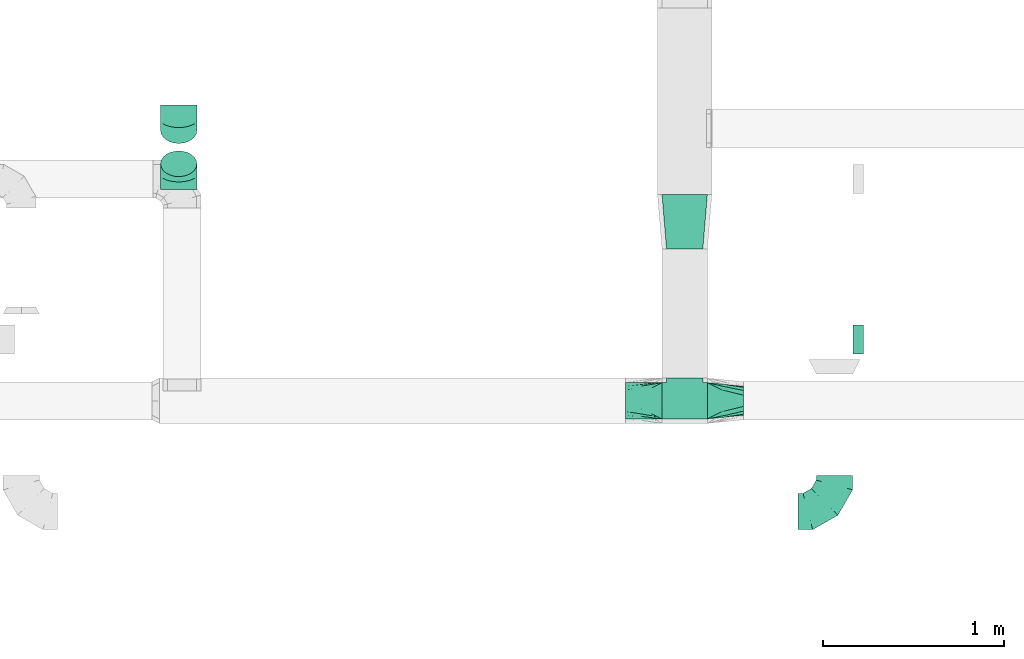
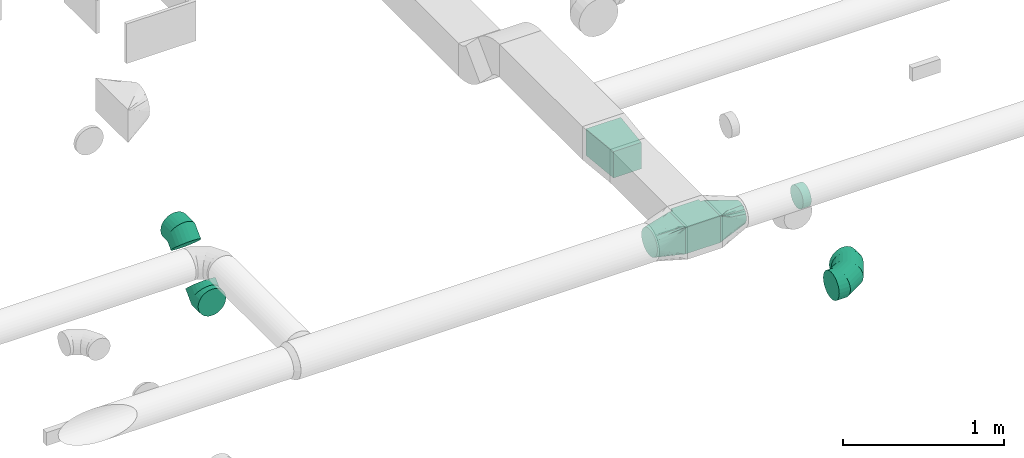
# One storey, part 37 of 62: 8 flow fittings.
"""IFC2X3 building model written with IfcOpenShell, lengths in millimetres."""

from ifc_helpers import new_model, entity, si_unit, converted_unit, derived_unit, direction, frame, origin, place, context, subcontext, project, spatial, polyline, outline, extrude, faceted_brep, source, transform, mapped, material, type_object, type_shapes, element, save


model = new_model("IFC2X3")

# Units and contexts
model_context = context("Model", 3, precision=0.01, world=origin(), true_north=direction((6.12303176911189e-17, 1.0)))
body_context = subcontext(model_context, "Body", "Model", "MODEL_VIEW")
ifc_project = project(units=[si_unit("LENGTHUNIT", "METRE", prefix="MILLI"), si_unit("AREAUNIT", "SQUARE_METRE"), si_unit("VOLUMEUNIT", "CUBIC_METRE"), converted_unit("PLANEANGLEUNIT", "DEGREE", entity("IfcRatioMeasure", 0.0174532925199433), si_unit("PLANEANGLEUNIT", "RADIAN"), dimensions=[0, 0, 0, 0, 0, 0, 0]), si_unit("MASSUNIT", "GRAM", prefix="KILO"), derived_unit("MASSDENSITYUNIT", [(si_unit("MASSUNIT", "GRAM", prefix="KILO"), 1), (si_unit("LENGTHUNIT", "METRE"), -3)]), derived_unit("MOMENTOFINERTIAUNIT", [(si_unit("LENGTHUNIT", "METRE"), 4)]), si_unit("TIMEUNIT", "SECOND"), si_unit("FREQUENCYUNIT", "HERTZ"), si_unit("THERMODYNAMICTEMPERATUREUNIT", "DEGREE_CELSIUS"), derived_unit("THERMALTRANSMITTANCEUNIT", [(si_unit("MASSUNIT", "GRAM", prefix="KILO"), 1), (si_unit("THERMODYNAMICTEMPERATUREUNIT", "KELVIN"), -1), (si_unit("TIMEUNIT", "SECOND"), -3)]), derived_unit("VOLUMETRICFLOWRATEUNIT", [(si_unit("LENGTHUNIT", "METRE"), 3), (si_unit("TIMEUNIT", "SECOND"), -1)]), derived_unit("MASSFLOWRATEUNIT", [(si_unit("MASSUNIT", "GRAM", prefix="KILO"), 1), (si_unit("TIMEUNIT", "SECOND"), -1)]), derived_unit("ROTATIONALFREQUENCYUNIT", [(si_unit("TIMEUNIT", "SECOND"), -1)]), si_unit("ELECTRICCURRENTUNIT", "AMPERE"), si_unit("ELECTRICVOLTAGEUNIT", "VOLT"), si_unit("POWERUNIT", "WATT"), si_unit("FORCEUNIT", "NEWTON", prefix="KILO"), si_unit("ILLUMINANCEUNIT", "LUX"), si_unit("LUMINOUSFLUXUNIT", "LUMEN"), si_unit("LUMINOUSINTENSITYUNIT", "CANDELA"), derived_unit("USERDEFINED", [(si_unit("MASSUNIT", "GRAM", prefix="KILO"), -1), (si_unit("LENGTHUNIT", "METRE"), -2), (si_unit("TIMEUNIT", "SECOND"), 3), (si_unit("LUMINOUSFLUXUNIT", "LUMEN"), 1)]), derived_unit("LINEARVELOCITYUNIT", [(si_unit("LENGTHUNIT", "METRE"), 1), (si_unit("TIMEUNIT", "SECOND"), -1)]), si_unit("PRESSUREUNIT", "PASCAL"), derived_unit("USERDEFINED", [(si_unit("LENGTHUNIT", "METRE"), -2), (si_unit("MASSUNIT", "GRAM", prefix="KILO"), 1), (si_unit("TIMEUNIT", "SECOND"), -2)]), derived_unit("LINEARFORCEUNIT", [(si_unit("MASSUNIT", "GRAM", prefix="KILO"), 1), (si_unit("LENGTHUNIT", "METRE"), 1), (si_unit("TIMEUNIT", "SECOND"), -2), (si_unit("LENGTHUNIT", "METRE"), -1)]), derived_unit("PLANARFORCEUNIT", [(si_unit("MASSUNIT", "GRAM", prefix="KILO"), 1), (si_unit("LENGTHUNIT", "METRE"), 1), (si_unit("TIMEUNIT", "SECOND"), -2), (si_unit("LENGTHUNIT", "METRE"), -2)])], contexts=[model_context])

# Site, building, storey
site_placement = place(None, origin())
site = spatial("IfcSite", under=ifc_project, at=site_placement, CompositionType="ELEMENT")
building_placement = place(site_placement, origin())
building = spatial("IfcBuilding", under=site, at=building_placement, CompositionType="ELEMENT")
storey_placement = place(building_placement, frame((0.0, 0.0, 24000.0)))
storey = spatial("IfcBuildingStorey", under=building, at=storey_placement, CompositionType="ELEMENT", Elevation=24000.0)

# Flow fittings
ifc_material = material()
duct_fitting_type_1 = type_object("IfcDuctFittingType", PredefinedType="NOTDEFINED", material=ifc_material)
shared_shape_1 = source(origin(), body_context, "Body", "SweptSolid", [
    extrude(outline(polyline([(-125.0, 43.75), (-125.0, -156.25), (125.0, -156.25), (125.0, 43.75), (100.0, 43.75), (100.0, 68.75), (-100.0, 68.75), (-100.0, 43.75), (-125.0, 43.75)])), frame((0.0, -56.25, -100.0), z_axis=(0.0, 0.0, -1.0), x_axis=(1.0, 0.0, 0.0)), (0.0, 0.0, -1.0), 200.0),
])
type_shapes(duct_fitting_type_1, [shared_shape_1])
flow_fitting_1_placement = place(storey_placement, frame((55179.59, 2775.97, 3550.0), z_axis=(0.0, 0.0, 1.0), x_axis=(-1.0, 0.0, 0.0)))
element("IfcFlowFitting", 1, at=flow_fitting_1_placement, inside=storey, type_object=duct_fitting_type_1, material=ifc_material, context=body_context, shape_type="MappedRepresentation", body=[
    mapped(shared_shape_1, transform((0.0, 0.0, 0.0), scale=1.0)),
])
duct_fitting_type_2 = type_object("IfcDuctFittingType", PredefinedType="NOTDEFINED", material=ifc_material)
shared_shape_2 = source(origin(), body_context, "Body", "SweptSolid", [
    extrude(outline(polyline([(-141.18, -112.11), (159.86, -112.11), (139.1, 137.03), (-157.79, 87.2), (-141.18, -112.11)])), frame((150.0, 0.0, -100.0), z_axis=(0.0, 0.0, 1.0), x_axis=(0.996545758244879, -0.0830454798537418, 0.0)), (0.0, 0.0, 1.0), 200.0),
])
type_shapes(duct_fitting_type_2, [shared_shape_2])
flow_fitting_2_placement = place(storey_placement, frame((55179.59, 3612.24, 3550.0), z_axis=(0.0, 0.0, 1.0), x_axis=(0.0, 1.0, 0.0)))
element("IfcFlowFitting", 2, at=flow_fitting_2_placement, inside=storey, type_object=duct_fitting_type_2, material=ifc_material, context=body_context, shape_type="MappedRepresentation", body=[
    mapped(shared_shape_2, transform((0.0, 0.0, 0.0), scale=1.0)),
])
duct_fitting_type_3 = type_object("IfcDuctFittingType", PredefinedType="NOTDEFINED", material=ifc_material)
shared_shape_3 = source(origin(), body_context, "Body", "Brep", [
    faceted_brep([(-200.0, 0.0, -100.0), (-200.0, -25.88, -96.59), (-200.0, -50.0, -86.6), (-200.0, -70.71, -70.71), (-200.0, -86.6, -50.0), (-200.0, -96.59, -25.88), (-200.0, -100.0, 0.0), (-200.0, -96.59, 25.88), (-200.0, -86.6, 50.0), (-200.0, -70.71, 70.71), (-200.0, -50.0, 86.6), (-200.0, -25.88, 96.59), (-200.0, 0.0, 100.0), (-200.0, 25.88, 96.59), (-200.0, 50.0, 86.6), (-200.0, 70.71, 70.71), (-200.0, 86.6, 50.0), (-200.0, 96.59, 25.88), (-200.0, 100.0, 0.0), (-200.0, 96.59, -25.88), (-200.0, 86.6, -50.0), (-200.0, 70.71, -70.71), (-200.0, 50.0, -86.6), (-200.0, 25.88, -96.59), (-153.35, 25.88, 96.59), (-159.81, 50.0, 86.6), (-146.41, 0.0, 100.0), (-165.36, 70.71, 70.71), (-172.29, 96.59, 25.88), (-173.21, 100.0, 0.0), (-169.62, 86.6, 50.0), (-169.62, 86.6, -50.0), (-165.36, 70.71, -70.71), (-172.29, 96.59, -25.88), (-153.35, 25.88, -96.59), (-146.41, 0.0, -100.0), (-159.81, 50.0, -86.6), (-139.48, -25.88, -96.59), (-133.01, -50.0, -86.6), (-127.46, -70.71, -70.71), (-123.21, -86.6, -50.0), (-120.53, -96.59, -25.88), (-119.62, -100.0, 0.0), (-120.53, -96.59, 25.88), (-123.21, -86.6, 50.0), (-127.46, -70.71, 70.71), (-133.01, -50.0, 86.6), (-139.48, -25.88, 96.59), (-72.54, 72.54, 96.59), (-90.19, 90.19, 86.6), (-53.59, 53.59, 100.0), (-105.35, 105.35, 70.71), (-116.99, 116.99, 50.0), (-124.3, 124.3, 25.88), (-126.79, 126.79, 0.0), (-124.3, 124.3, -25.88), (-116.99, 116.99, -50.0), (-105.35, 105.35, -70.71), (-72.54, 72.54, -96.59), (-53.59, 53.59, -100.0), (-90.19, 90.19, -86.6), (-34.64, 34.64, -96.59), (-16.99, 16.99, -86.6), (-1.83, 1.83, -70.71), (9.81, -9.81, -50.0), (17.12, -17.12, -25.88), (19.62, -19.62, 0.0), (17.12, -17.12, 25.88), (9.81, -9.81, 50.0), (-1.83, 1.83, 70.71), (-16.99, 16.99, 86.6), (-34.64, 34.64, 96.59), (-25.88, 153.35, 96.59), (-50.0, 159.81, 86.6), (0.0, 146.41, 100.0), (-70.71, 165.36, 70.71), (-86.6, 169.62, 50.0), (-96.59, 172.29, 25.88), (-100.0, 173.21, 0.0), (-96.59, 172.29, -25.88), (-86.6, 169.62, -50.0), (-70.71, 165.36, -70.71), (-25.88, 153.35, -96.59), (0.0, 146.41, -100.0), (-50.0, 159.81, -86.6), (25.88, 139.48, -96.59), (50.0, 133.01, -86.6), (70.71, 127.46, -70.71), (86.6, 123.21, -50.0), (96.59, 120.53, -25.88), (100.0, 119.62, 0.0), (96.59, 120.53, 25.88), (86.6, 123.21, 50.0), (70.71, 127.46, 70.71), (50.0, 133.01, 86.6), (25.88, 139.48, 96.59), (-25.88, 200.0, -96.59), (-50.0, 200.0, -86.6), (-70.71, 200.0, -70.71), (-86.6, 200.0, -50.0), (-96.59, 200.0, -25.88), (-100.0, 200.0, 0.0), (-96.59, 200.0, 25.88), (-86.6, 200.0, 50.0), (-70.71, 200.0, 70.71), (-50.0, 200.0, 86.6), (-25.88, 200.0, 96.59), (0.0, 200.0, 100.0), (25.88, 200.0, 96.59), (50.0, 200.0, 86.6), (70.71, 200.0, 70.71), (86.6, 200.0, 50.0), (96.59, 200.0, 25.88), (100.0, 200.0, 0.0), (96.59, 200.0, -25.88), (86.6, 200.0, -50.0), (70.71, 200.0, -70.71), (50.0, 200.0, -86.6), (25.88, 200.0, -96.59), (0.0, 200.0, -100.0)], [[[0, 1, 2, 3, 4, 5, 6, 7, 8, 9, 10, 11, 12, 13, 14, 15, 16, 17, 18, 19, 20, 21, 22, 23]], [[24, 25, 14, 13]], [[26, 24, 13, 12]], [[14, 25, 27, 15]], [[28, 29, 18, 17]], [[30, 28, 17, 16]], [[15, 27, 30, 16]], [[20, 31, 32, 21]], [[33, 31, 20, 19]], [[18, 29, 33, 19]], [[34, 35, 0, 23]], [[36, 34, 23, 22]], [[32, 36, 22, 21]], [[1, 0, 35, 37]], [[2, 1, 37, 38]], [[38, 39, 3, 2]], [[5, 4, 40, 41]], [[6, 5, 41, 42]], [[39, 40, 4, 3]], [[6, 42, 43, 7]], [[7, 43, 44, 8]], [[8, 44, 45, 9]], [[9, 45, 46, 10]], [[10, 46, 47, 11]], [[26, 12, 11, 47]], [[48, 49, 25, 24]], [[50, 48, 24, 26]], [[27, 25, 49, 51]], [[52, 53, 28, 30]], [[51, 52, 30, 27]], [[29, 28, 53, 54]], [[55, 56, 31, 33]], [[54, 55, 33, 29]], [[32, 31, 56, 57]], [[58, 59, 35, 34]], [[60, 58, 34, 36]], [[57, 60, 36, 32]], [[37, 35, 59, 61]], [[38, 37, 61, 62]], [[39, 38, 62, 63]], [[41, 40, 64, 65]], [[42, 41, 65, 66]], [[63, 64, 40, 39]], [[43, 42, 66, 67]], [[44, 43, 67, 68]], [[68, 69, 45, 44]], [[46, 45, 69, 70]], [[47, 46, 70, 71]], [[26, 47, 71, 50]], [[72, 73, 49, 48]], [[74, 72, 48, 50]], [[51, 49, 73, 75]], [[76, 77, 53, 52]], [[75, 76, 52, 51]], [[54, 53, 77, 78]], [[79, 80, 56, 55]], [[78, 79, 55, 54]], [[57, 56, 80, 81]], [[82, 83, 59, 58]], [[84, 82, 58, 60]], [[81, 84, 60, 57]], [[61, 59, 83, 85]], [[62, 61, 85, 86]], [[63, 62, 86, 87]], [[65, 64, 88, 89]], [[66, 65, 89, 90]], [[87, 88, 64, 63]], [[67, 66, 90, 91]], [[68, 67, 91, 92]], [[92, 93, 69, 68]], [[70, 69, 93, 94]], [[71, 70, 94, 95]], [[50, 71, 95, 74]], [[96, 97, 98, 99, 100, 101, 102, 103, 104, 105, 106, 107, 108, 109, 110, 111, 112, 113, 114, 115, 116, 117, 118, 119]], [[72, 74, 107, 106]], [[73, 72, 106, 105]], [[75, 73, 105, 104]], [[102, 101, 78, 77]], [[103, 102, 77, 76]], [[75, 104, 103, 76]], [[78, 101, 100, 79]], [[79, 100, 99, 80]], [[80, 99, 98, 81]], [[84, 97, 96, 82]], [[82, 96, 119, 83]], [[84, 81, 98, 97]], [[118, 117, 86, 85]], [[119, 118, 85, 83]], [[116, 87, 86, 117]], [[88, 115, 114, 89]], [[89, 114, 113, 90]], [[115, 88, 87, 116]], [[91, 90, 113, 112]], [[92, 91, 112, 111]], [[111, 110, 93, 92]], [[95, 94, 109, 108]], [[74, 95, 108, 107]], [[110, 109, 94, 93]]]),
])
type_shapes(duct_fitting_type_3, [shared_shape_3])
flow_fitting_3_placement = place(storey_placement, frame((56004.94, 2165.61, 3260.0)))
element("IfcFlowFitting", 3, at=flow_fitting_3_placement, inside=storey, type_object=duct_fitting_type_3, material=ifc_material, context=body_context, shape_type="MappedRepresentation", body=[
    mapped(shared_shape_3, transform((0.0, 0.0, 0.0), scale=1.0)),
])
duct_fitting_type_4 = type_object("IfcDuctFittingType", PredefinedType="NOTDEFINED", material=ifc_material)
shared_shape_4 = source(origin(), body_context, "Body", "Brep", [
    faceted_brep([(-82.84, 0.0, -100.0), (-82.84, -25.88, -96.59), (-82.84, -50.0, -86.6), (-82.84, -70.71, -70.71), (-82.84, -86.6, -50.0), (-82.84, -96.59, -25.88), (-82.84, -100.0, 0.0), (-82.84, -96.59, 25.88), (-82.84, -86.6, 50.0), (-82.84, -70.71, 70.71), (-82.84, -50.0, 86.6), (-82.84, -25.88, 96.59), (-82.84, 0.0, 100.0), (-82.84, 25.88, 96.59), (-82.84, 50.0, 86.6), (-82.84, 70.71, 70.71), (-82.84, 86.6, 50.0), (-82.84, 96.59, 25.88), (-82.84, 100.0, 0.0), (-82.84, 96.59, -25.88), (-82.84, 86.6, -50.0), (-82.84, 70.71, -70.71), (-82.84, 50.0, -86.6), (-82.84, 25.88, -96.59), (-10.72, 25.88, 96.59), (-20.71, 50.0, 86.6), (0.0, 0.0, 100.0), (-29.29, 70.71, 70.71), (-35.87, 86.6, 50.0), (-40.01, 96.59, 25.88), (-41.42, 100.0, 0.0), (-40.01, 96.59, -25.88), (-35.87, 86.6, -50.0), (-29.29, 70.71, -70.71), (-10.72, 25.88, -96.59), (0.0, 0.0, -100.0), (-20.71, 50.0, -86.6), (10.72, -25.88, -96.59), (20.71, -50.0, -86.6), (29.29, -70.71, -70.71), (35.87, -86.6, -50.0), (40.01, -96.59, -25.88), (41.42, -100.0, 0.0), (40.01, -96.59, 25.88), (35.87, -86.6, 50.0), (29.29, -70.71, 70.71), (20.71, -50.0, 86.6), (10.72, -25.88, 96.59), (58.58, 58.58, 100.0), (40.28, 76.88, 96.59), (23.22, 93.93, 86.6), (8.58, 108.58, 70.71), (-2.66, 119.82, 50.0), (-9.72, 126.88, 25.88), (-12.13, 129.29, 0.0), (-9.72, 126.88, -25.88), (-2.66, 119.82, -50.0), (8.58, 108.58, -70.71), (23.22, 93.93, -86.6), (40.28, 76.88, -96.59), (58.58, 58.58, -100.0), (76.88, 40.28, -96.59), (93.93, 23.22, -86.6), (108.58, 8.58, -70.71), (119.82, -2.66, -50.0), (126.88, -9.72, -25.88), (129.29, -12.13, 0.0), (126.88, -9.72, 25.88), (119.82, -2.66, 50.0), (108.58, 8.58, 70.71), (93.93, 23.22, 86.6), (76.88, 40.28, 96.59)], [[[0, 1, 2, 3, 4, 5, 6, 7, 8, 9, 10, 11, 12, 13, 14, 15, 16, 17, 18, 19, 20, 21, 22, 23]], [[24, 25, 14, 13]], [[26, 24, 13, 12]], [[14, 25, 27, 15]], [[28, 29, 17, 16]], [[28, 16, 15, 27]], [[30, 18, 17, 29]], [[31, 32, 20, 19]], [[30, 31, 19, 18]], [[32, 33, 21, 20]], [[34, 35, 0, 23]], [[36, 34, 23, 22]], [[33, 36, 22, 21]], [[1, 0, 35, 37]], [[2, 1, 37, 38]], [[38, 39, 3, 2]], [[5, 4, 40, 41]], [[6, 5, 41, 42]], [[39, 40, 4, 3]], [[6, 42, 43, 7]], [[7, 43, 44, 8]], [[8, 44, 45, 9]], [[9, 45, 46, 10]], [[10, 46, 47, 11]], [[26, 12, 11, 47]], [[24, 26, 48, 49]], [[25, 24, 49, 50]], [[27, 25, 50, 51]], [[29, 28, 52, 53]], [[30, 29, 53, 54]], [[51, 52, 28, 27]], [[30, 54, 55, 31]], [[31, 55, 56, 32]], [[57, 33, 32, 56]], [[36, 58, 59, 34]], [[34, 59, 60, 35]], [[58, 36, 33, 57]], [[35, 60, 61, 37]], [[37, 61, 62, 38]], [[63, 39, 38, 62]], [[40, 64, 65, 41]], [[41, 65, 66, 42]], [[64, 40, 39, 63]], [[43, 42, 66, 67]], [[44, 43, 67, 68]], [[68, 69, 45, 44]], [[47, 46, 70, 71]], [[26, 47, 71, 48]], [[69, 70, 46, 45]], [[59, 58, 57, 56, 55, 54, 53, 52, 51, 50, 49, 48, 71, 70, 69, 68, 67, 66, 65, 64, 63, 62, 61, 60]]]),
])
type_shapes(duct_fitting_type_4, [shared_shape_4])
for number, where, z_axis, x_axis in (
    (4, (52391.36, 4023.41, 3250.0), (-1.0, 0.0, 0.0), (0.0, -0.70710678118653, -0.707106781186565)),
    (5, (52391.36, 4323.41, 3550.0), (-1.0, 0.0, 0.0), (0.0, 0.707106781186507, 0.707106781186588)),
):
    element("IfcFlowFitting", number, at=place(storey_placement, frame(where, z_axis=z_axis, x_axis=x_axis)), inside=storey, type_object=duct_fitting_type_4, material=ifc_material, context=body_context, shape_type="MappedRepresentation", body=[
        mapped(shared_shape_4, transform((0.0, 0.0, 0.0), scale=1.0)),
    ])
duct_fitting_type_5 = type_object("IfcDuctFittingType", PredefinedType="NOTDEFINED", material=ifc_material)
shared_shape_5 = source(origin(), body_context, "Body", "Brep", [
    faceted_brep([(200.0, 30.9, 95.11), (200.0, 19.08, 96.98), (200.0, 9.54, 98.49), (200.0, 4.77, 99.24), (200.0, 0.0, 100.0), (200.0, -4.77, 99.24), (200.0, -9.54, 98.49), (200.0, -19.08, 96.98), (200.0, -30.9, 95.11), (200.0, -44.84, 88.0), (200.0, -58.78, 80.9), (200.0, -69.84, 69.84), (200.0, -80.9, 58.78), (200.0, -88.0, 44.84), (200.0, -95.11, 30.9), (200.0, -96.98, 19.08), (200.0, -98.49, 9.54), (200.0, -99.24, 4.77), (200.0, -100.0, 0.0), (200.0, -99.24, -4.77), (200.0, -98.49, -9.54), (200.0, -96.98, -19.08), (200.0, -95.11, -30.9), (200.0, -88.0, -44.84), (200.0, -80.9, -58.78), (200.0, -69.84, -69.84), (200.0, -58.78, -80.9), (200.0, -44.84, -88.0), (200.0, -30.9, -95.11), (200.0, -19.08, -96.98), (200.0, -9.54, -98.49), (200.0, -4.77, -99.24), (200.0, 0.0, -100.0), (200.0, 4.77, -99.24), (200.0, 9.54, -98.49), (200.0, 19.08, -96.98), (200.0, 30.9, -95.11), (200.0, 44.84, -88.0), (200.0, 58.78, -80.9), (200.0, 69.84, -69.84), (200.0, 80.9, -58.78), (200.0, 88.0, -44.84), (200.0, 95.11, -30.9), (200.0, 96.98, -19.08), (200.0, 98.49, -9.54), (200.0, 99.24, -4.77), (200.0, 100.0, 0.0), (200.0, 99.24, 4.77), (200.0, 98.49, 9.54), (200.0, 96.98, 19.08), (200.0, 95.11, 30.9), (200.0, 88.0, 44.84), (200.0, 80.9, 58.78), (200.0, 69.84, 69.84), (200.0, 58.78, 80.9), (200.0, 44.84, 88.0), (0.0, -100.0, 100.0), (0.0, 100.0, 100.0), (0.0, 100.0, -100.0), (0.0, -100.0, -100.0), (104.11, -47.94, 100.0), (100.0, -83.15, 87.43), (26.03, -86.99, 100.0), (78.09, -60.96, 100.0), (52.06, -73.97, 100.0), (188.01, -5.99, 100.0), (176.03, -11.99, 100.0), (152.06, -23.97, 100.0), (128.09, -35.96, 100.0), (52.06, -100.0, 73.97), (78.09, -100.0, 60.96), (104.11, -100.0, 47.94), (128.09, -100.0, 35.96), (152.06, -100.0, 23.97), (176.03, -100.0, 11.99), (188.01, -100.0, 5.99), (26.03, -100.0, 86.99), (26.03, -100.0, -86.99), (52.06, -100.0, -73.97), (78.09, -100.0, -60.96), (104.11, -100.0, -47.94), (128.09, -100.0, -35.96), (152.06, -100.0, -23.97), (176.03, -100.0, -11.99), (188.01, -100.0, -5.99), (100.0, -87.43, -83.15), (52.06, -73.97, -100.0), (78.09, -60.96, -100.0), (104.11, -47.94, -100.0), (128.09, -35.96, -100.0), (152.06, -23.97, -100.0), (176.03, -11.99, -100.0), (188.01, -5.99, -100.0), (26.03, -86.99, -100.0), (26.03, 86.99, -100.0), (52.06, 73.97, -100.0), (78.09, 60.96, -100.0), (104.11, 47.94, -100.0), (128.09, 35.96, -100.0), (152.06, 23.97, -100.0), (176.03, 11.99, -100.0), (188.01, 5.99, -100.0), (100.0, 83.15, -87.43), (52.06, 100.0, -73.97), (78.09, 100.0, -60.96), (104.11, 100.0, -47.94), (128.09, 100.0, -35.96), (152.06, 100.0, -23.97), (176.03, 100.0, -11.99), (188.01, 100.0, -5.99), (26.03, 100.0, -86.99), (26.03, 100.0, 86.99), (52.06, 100.0, 73.97), (78.09, 100.0, 60.96), (104.11, 100.0, 47.94), (128.09, 100.0, 35.96), (152.06, 100.0, 23.97), (176.03, 100.0, 11.99), (188.01, 100.0, 5.99), (100.0, 87.43, 83.15), (52.06, 73.97, 100.0), (78.09, 60.96, 100.0), (104.11, 47.94, 100.0), (128.09, 35.96, 100.0), (152.06, 23.97, 100.0), (176.03, 11.99, 100.0), (188.01, 5.99, 100.0), (26.03, 86.99, 100.0)], [[[0, 1, 2, 3, 4, 5, 6, 7, 8, 9, 10, 11, 12, 13, 14, 15, 16, 17, 18, 19, 20, 21, 22, 23, 24, 25, 26, 27, 28, 29, 30, 31, 32, 33, 34, 35, 36, 37, 38, 39, 40, 41, 42, 43, 44, 45, 46, 47, 48, 49, 50, 51, 52, 53, 54, 55]], [[56, 57, 58, 59]], [[60, 9, 8]], [[56, 61, 62]], [[9, 60, 63, 64]], [[65, 66, 67, 68, 60, 8, 7, 6, 5, 4]], [[62, 61, 10]], [[13, 69, 70, 71]], [[64, 10, 9]], [[14, 71, 72, 73, 74, 75, 18, 17, 16, 15]], [[12, 76, 69]], [[71, 14, 13]], [[61, 76, 11]], [[10, 64, 62]], [[76, 12, 11]], [[10, 61, 11]], [[61, 56, 76]], [[69, 13, 12]], [[75, 74, 73, 72, 71, 70, 69, 76, 56, 59, 77, 78, 79, 80, 81, 82, 83, 84, 18]], [[80, 23, 22]], [[59, 85, 77]], [[23, 80, 79, 78]], [[84, 83, 82, 81, 80, 22, 21, 20, 19, 18]], [[77, 85, 24]], [[27, 86, 87, 88]], [[78, 24, 23]], [[28, 88, 89, 90, 91, 92, 32, 31, 30, 29]], [[26, 93, 86]], [[88, 28, 27]], [[85, 93, 25]], [[24, 78, 77]], [[93, 26, 25]], [[24, 85, 25]], [[85, 59, 93]], [[86, 27, 26]], [[92, 91, 90, 89, 88, 87, 86, 93, 59, 58, 94, 95, 96, 97, 98, 99, 100, 101, 32]], [[97, 37, 36]], [[58, 102, 94]], [[37, 97, 96, 95]], [[101, 100, 99, 98, 97, 36, 35, 34, 33, 32]], [[94, 102, 38]], [[41, 103, 104, 105]], [[95, 38, 37]], [[42, 105, 106, 107, 108, 109, 46, 45, 44, 43]], [[40, 110, 103]], [[105, 42, 41]], [[102, 110, 39]], [[38, 95, 94]], [[110, 40, 39]], [[38, 102, 39]], [[102, 58, 110]], [[103, 41, 40]], [[58, 57, 111, 112, 113, 114, 115, 116, 117, 118, 46, 109, 108, 107, 106, 105, 104, 103, 110]], [[114, 51, 50]], [[57, 119, 111]], [[51, 114, 113, 112]], [[118, 117, 116, 115, 114, 50, 49, 48, 47, 46]], [[111, 119, 52]], [[55, 120, 121, 122]], [[112, 52, 51]], [[0, 122, 123, 124, 125, 126, 4, 3, 2, 1]], [[54, 127, 120]], [[122, 0, 55]], [[119, 127, 53]], [[52, 112, 111]], [[127, 54, 53]], [[52, 119, 53]], [[119, 57, 127]], [[120, 55, 54]], [[57, 56, 62, 64, 63, 60, 68, 67, 66, 65, 4, 126, 125, 124, 123, 122, 121, 120, 127]]]),
])
type_shapes(duct_fitting_type_5, [shared_shape_5])
flow_fitting_4_placement = place(storey_placement, frame((55054.59, 2775.97, 3550.0), z_axis=(0.0, 0.0, 1.0), x_axis=(-1.0, 0.0, 0.0)))
element("IfcFlowFitting", 6, at=flow_fitting_4_placement, inside=storey, type_object=duct_fitting_type_5, material=ifc_material, context=body_context, shape_type="MappedRepresentation", body=[
    mapped(shared_shape_5, transform((0.0, 0.0, 0.0), scale=1.0)),
])
duct_fitting_type_6 = type_object("IfcDuctFittingType", PredefinedType="NOTDEFINED", material=ifc_material)
shared_shape_6 = source(origin(), body_context, "Body", "Brep", [
    faceted_brep([(200.0, 30.61, 73.91), (200.0, 22.87, 75.45), (200.0, 15.12, 76.99), (200.0, 11.34, 77.74), (200.0, 7.56, 78.5), (200.0, 0.0, 80.0), (200.0, -7.56, 78.5), (200.0, -15.12, 76.99), (200.0, -18.99, 76.22), (200.0, -22.87, 75.45), (200.0, -30.61, 73.91), (200.0, -37.1, 69.57), (200.0, -43.59, 65.24), (200.0, -50.08, 60.9), (200.0, -56.57, 56.57), (200.0, -60.9, 50.08), (200.0, -65.24, 43.59), (200.0, -69.57, 37.1), (200.0, -73.91, 30.61), (200.0, -75.45, 22.87), (200.0, -76.99, 15.12), (200.0, -77.74, 11.34), (200.0, -78.5, 7.56), (200.0, -80.0, 0.0), (200.0, -78.5, -7.56), (200.0, -76.99, -15.12), (200.0, -76.22, -18.99), (200.0, -75.45, -22.87), (200.0, -73.91, -30.61), (200.0, -69.57, -37.1), (200.0, -65.24, -43.59), (200.0, -60.9, -50.08), (200.0, -56.57, -56.57), (200.0, -50.08, -60.9), (200.0, -43.59, -65.24), (200.0, -37.1, -69.57), (200.0, -30.61, -73.91), (200.0, -22.87, -75.45), (200.0, -15.12, -76.99), (200.0, -11.34, -77.74), (200.0, -7.56, -78.5), (200.0, 0.0, -80.0), (200.0, 7.56, -78.5), (200.0, 15.12, -76.99), (200.0, 18.99, -76.22), (200.0, 22.87, -75.45), (200.0, 30.61, -73.91), (200.0, 37.1, -69.57), (200.0, 43.59, -65.24), (200.0, 50.08, -60.9), (200.0, 56.57, -56.57), (200.0, 60.9, -50.08), (200.0, 65.24, -43.59), (200.0, 69.57, -37.1), (200.0, 73.91, -30.61), (200.0, 75.45, -22.87), (200.0, 76.99, -15.12), (200.0, 77.74, -11.34), (200.0, 78.5, -7.56), (200.0, 80.0, 0.0), (200.0, 78.5, 7.56), (200.0, 76.99, 15.12), (200.0, 76.22, 18.99), (200.0, 75.45, 22.87), (200.0, 73.91, 30.61), (200.0, 69.57, 37.1), (200.0, 65.24, 43.59), (200.0, 60.9, 50.08), (200.0, 56.57, 56.57), (200.0, 50.08, 60.9), (200.0, 43.59, 65.24), (200.0, 37.1, 69.57), (0.0, -100.0, 100.0), (0.0, 100.0, 100.0), (0.0, 100.0, -100.0), (0.0, -100.0, -100.0), (52.06, -73.97, 94.79), (78.09, -60.96, 92.19), (176.03, -11.99, 82.4), (152.06, -23.97, 84.79), (128.09, -35.96, 87.19), (104.11, -47.94, 89.59), (100.0, -79.94, 76.52), (78.09, -92.19, 60.96), (104.11, -89.59, 47.94), (128.09, -87.19, 35.96), (152.06, -84.79, 23.97), (164.04, -83.6, 17.98), (176.03, -82.4, 11.99), (26.03, -97.4, 86.99), (52.06, -94.79, 73.97), (26.03, -86.99, 97.4), (26.03, -97.4, -86.99), (52.06, -94.79, -73.97), (78.09, -92.19, -60.96), (104.11, -89.59, -47.94), (128.09, -87.19, -35.96), (152.06, -84.79, -23.97), (176.03, -82.4, -11.99), (100.0, -76.52, -79.94), (78.09, -60.96, -92.19), (104.11, -47.94, -89.59), (128.09, -35.96, -87.19), (152.06, -23.97, -84.79), (164.04, -17.98, -83.6), (176.03, -11.99, -82.4), (26.03, -86.99, -97.4), (52.06, -73.97, -94.79), (26.03, 86.99, -97.4), (52.06, 73.97, -94.79), (78.09, 60.96, -92.19), (104.11, 47.94, -89.59), (128.09, 35.96, -87.19), (152.06, 23.97, -84.79), (176.03, 11.99, -82.4), (100.0, 79.94, -76.52), (78.09, 92.19, -60.96), (104.11, 89.59, -47.94), (128.09, 87.19, -35.96), (152.06, 84.79, -23.97), (164.04, 83.6, -17.98), (176.03, 82.4, -11.99), (26.03, 97.4, -86.99), (52.06, 94.79, -73.97), (26.03, 97.4, 86.99), (52.06, 94.79, 73.97), (78.09, 92.19, 60.96), (104.11, 89.59, 47.94), (128.09, 87.19, 35.96), (152.06, 84.79, 23.97), (176.03, 82.4, 11.99), (100.0, 76.52, 79.94), (78.09, 60.96, 92.19), (104.11, 47.94, 89.59), (128.09, 35.96, 87.19), (152.06, 23.97, 84.79), (164.04, 17.98, 83.6), (176.03, 11.99, 82.4), (26.03, 86.99, 97.4), (52.06, 73.97, 94.79)], [[[0, 1, 2, 3, 4, 5, 6, 7, 8, 9, 10, 11, 12, 13, 14, 15, 16, 17, 18, 19, 20, 21, 22, 23, 24, 25, 26, 27, 28, 29, 30, 31, 32, 33, 34, 35, 36, 37, 38, 39, 40, 41, 42, 43, 44, 45, 46, 47, 48, 49, 50, 51, 52, 53, 54, 55, 56, 57, 58, 59, 60, 61, 62, 63, 64, 65, 66, 67, 68, 69, 70, 71]], [[72, 73, 74, 75]], [[76, 12, 77]], [[12, 11, 10, 77]], [[78, 79, 80, 81, 77, 10, 9, 8, 7, 6, 5]], [[13, 82, 14]], [[20, 19, 18, 83, 84, 85, 86, 87, 88, 23, 22, 21]], [[82, 72, 89]], [[82, 15, 14]], [[83, 16, 90]], [[91, 72, 82]], [[18, 17, 16, 83]], [[90, 16, 15]], [[15, 82, 89]], [[90, 15, 89]], [[76, 13, 12]], [[13, 76, 91]], [[82, 13, 91]], [[88, 87, 86, 85, 84, 83, 90, 89, 72, 75, 92, 93, 94, 95, 96, 97, 98, 23]], [[93, 30, 94]], [[30, 29, 28, 94]], [[98, 97, 96, 95, 94, 28, 27, 26, 25, 24, 23]], [[31, 99, 32]], [[38, 37, 36, 100, 101, 102, 103, 104, 105, 41, 40, 39]], [[99, 75, 106]], [[99, 33, 32]], [[100, 34, 107]], [[92, 75, 99]], [[36, 35, 34, 100]], [[107, 34, 33]], [[33, 99, 106]], [[107, 33, 106]], [[93, 31, 30]], [[31, 93, 92]], [[99, 31, 92]], [[105, 104, 103, 102, 101, 100, 107, 106, 75, 74, 108, 109, 110, 111, 112, 113, 114, 41]], [[109, 48, 110]], [[48, 47, 46, 110]], [[114, 113, 112, 111, 110, 46, 45, 44, 43, 42, 41]], [[49, 115, 50]], [[56, 55, 54, 116, 117, 118, 119, 120, 121, 59, 58, 57]], [[115, 74, 122]], [[115, 51, 50]], [[116, 52, 123]], [[108, 74, 115]], [[54, 53, 52, 116]], [[123, 52, 51]], [[51, 115, 122]], [[123, 51, 122]], [[109, 49, 48]], [[49, 109, 108]], [[115, 49, 108]], [[74, 73, 124, 125, 126, 127, 128, 129, 130, 59, 121, 120, 119, 118, 117, 116, 123, 122]], [[125, 66, 126]], [[66, 65, 64, 126]], [[130, 129, 128, 127, 126, 64, 63, 62, 61, 60, 59]], [[67, 131, 68]], [[2, 1, 0, 132, 133, 134, 135, 136, 137, 5, 4, 3]], [[131, 73, 138]], [[131, 69, 68]], [[132, 70, 139]], [[124, 73, 131]], [[0, 71, 70, 132]], [[139, 70, 69]], [[69, 131, 138]], [[139, 69, 138]], [[125, 67, 66]], [[67, 125, 124]], [[131, 67, 124]], [[73, 72, 91, 76, 77, 81, 80, 79, 78, 5, 137, 136, 135, 134, 133, 132, 139, 138]]]),
])
type_shapes(duct_fitting_type_6, [shared_shape_6])
flow_fitting_5_placement = place(storey_placement, frame((55304.59, 2775.97, 3550.0)))
element("IfcFlowFitting", 7, at=flow_fitting_5_placement, inside=storey, type_object=duct_fitting_type_6, material=ifc_material, context=body_context, shape_type="MappedRepresentation", body=[
    mapped(shared_shape_6, transform((0.0, 0.0, 0.0), scale=1.0)),
])
duct_fitting_type_7 = type_object("IfcDuctFittingType", PredefinedType="NOTDEFINED", material=ifc_material)
shared_shape_7 = source(origin(), body_context, "Body", "Brep", [
    faceted_brep([(20.02, 0.0, -80.0), (20.02, 20.71, -77.27), (20.02, 40.0, -69.28), (20.02, 56.57, -56.57), (20.02, 69.28, -40.0), (20.02, 77.27, -20.71), (20.02, 80.0, 0.0), (20.02, 77.27, 20.71), (20.02, 69.28, 40.0), (20.02, 56.57, 56.57), (20.02, 40.0, 69.28), (20.02, 20.71, 77.27), (20.02, 0.0, 80.0), (20.02, -20.71, 77.27), (20.02, -40.0, 69.28), (20.02, -56.57, 56.57), (20.02, -69.28, 40.0), (20.02, -77.27, 20.71), (20.02, -80.0, 0.0), (20.02, -77.27, -20.71), (20.02, -69.28, -40.0), (20.02, -56.57, -56.57), (20.02, -40.0, -69.28), (20.02, -20.71, -77.27), (0.0, 0.0, 80.0), (-38.52, 0.0, 80.0), (-38.52, -20.71, 77.27), (0.0, -20.71, 77.27), (-38.52, -40.0, 69.28), (0.0, -40.0, 69.28), (0.0, -56.57, 56.57), (-38.52, -56.57, 56.57), (0.0, -69.28, 40.0), (-38.52, -69.28, 40.0), (-38.52, -77.27, 20.71), (0.0, -77.27, 20.71), (-38.52, -80.0, 0.0), (0.0, -80.0, 0.0), (-38.52, -77.27, -20.71), (0.0, -77.27, -20.71), (-38.52, -69.28, -40.0), (0.0, -69.28, -40.0), (0.0, -56.57, -56.57), (-38.52, -56.57, -56.57), (0.0, -40.0, -69.28), (-38.52, -40.0, -69.28), (-38.52, -20.71, -77.27), (0.0, -20.71, -77.27), (-38.52, 0.0, -80.0), (0.0, 0.0, -80.0), (-38.52, 20.71, -77.27), (0.0, 20.71, -77.27), (-38.52, 40.0, -69.28), (0.0, 40.0, -69.28), (0.0, 56.57, -56.57), (-38.52, 56.57, -56.57), (0.0, 69.28, -40.0), (-38.52, 69.28, -40.0), (-38.52, 77.27, -20.71), (0.0, 77.27, -20.71), (-38.52, 80.0, 0.0), (0.0, 80.0, 0.0), (-38.52, 77.27, 20.71), (0.0, 77.27, 20.71), (-38.52, 69.28, 40.0), (0.0, 69.28, 40.0), (0.0, 56.57, 56.57), (-38.52, 56.57, 56.57), (0.0, 40.0, 69.28), (-38.52, 40.0, 69.28), (-38.52, 20.71, 77.27), (0.0, 20.71, 77.27)], [[[0, 1, 2, 3, 4, 5, 6, 7, 8, 9, 10, 11, 12, 13, 14, 15, 16, 17, 18, 19, 20, 21, 22, 23]], [[13, 12, 24, 25, 26, 27]], [[14, 13, 27, 26, 28, 29]], [[30, 15, 14, 29, 28, 31]], [[17, 16, 32, 33, 34, 35]], [[18, 17, 35, 34, 36, 37]], [[32, 16, 15, 30, 31, 33]], [[19, 18, 37, 36, 38, 39]], [[20, 19, 39, 38, 40, 41]], [[42, 21, 20, 41, 40, 43]], [[23, 22, 44, 45, 46, 47]], [[0, 23, 47, 46, 48, 49]], [[44, 22, 21, 42, 43, 45]], [[1, 0, 49, 48, 50, 51]], [[2, 1, 51, 50, 52, 53]], [[54, 3, 2, 53, 52, 55]], [[5, 4, 56, 57, 58, 59]], [[6, 5, 59, 58, 60, 61]], [[56, 4, 3, 54, 55, 57]], [[7, 6, 61, 60, 62, 63]], [[8, 7, 63, 62, 64, 65]], [[66, 9, 8, 65, 64, 67]], [[11, 10, 68, 69, 70, 71]], [[12, 11, 71, 70, 25, 24]], [[68, 10, 9, 66, 67, 69]], [[46, 45, 43, 40, 38, 36, 34, 33, 31, 28, 26, 25, 70, 69, 67, 64, 62, 60, 58, 57, 55, 52, 50, 48]]]),
])
type_shapes(duct_fitting_type_7, [shared_shape_7])
flow_fitting_6_placement = place(storey_placement, frame((56144.6, 3114.24, 3250.0), z_axis=(0.0, 0.0, -1.0), x_axis=(1.0, 0.0, 0.0)))
element("IfcFlowFitting", 8, at=flow_fitting_6_placement, inside=storey, type_object=duct_fitting_type_7, material=ifc_material, context=body_context, shape_type="MappedRepresentation", body=[
    mapped(shared_shape_7, transform((0.0, 0.0, 0.0), scale=1.0)),
])

save(model, "model.ifc")
